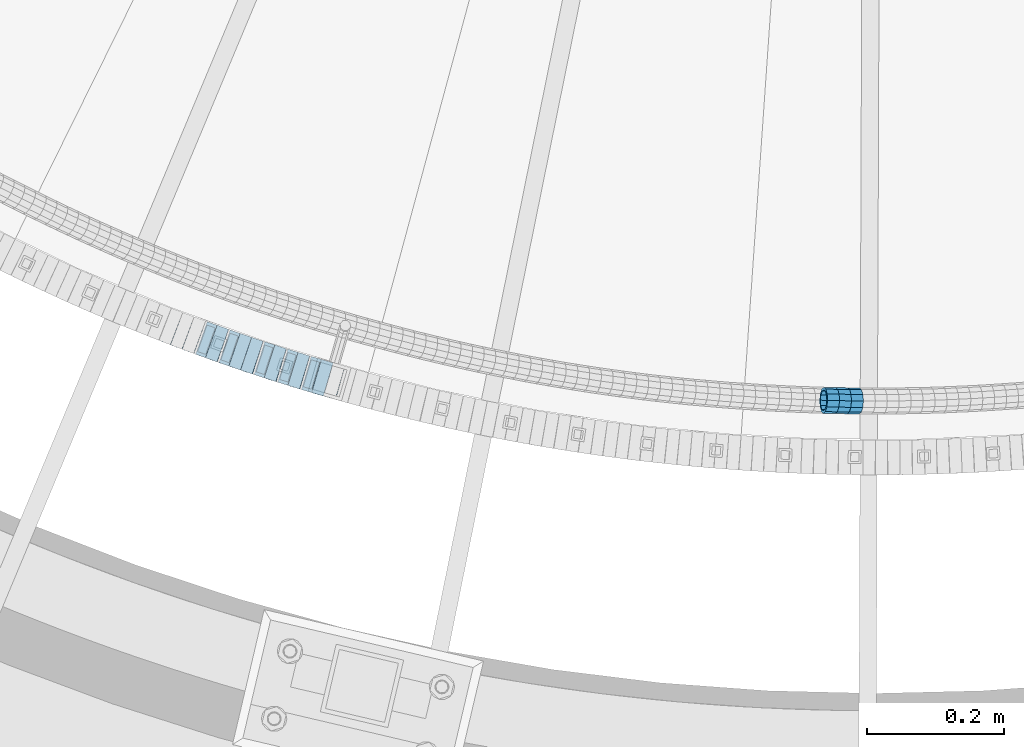
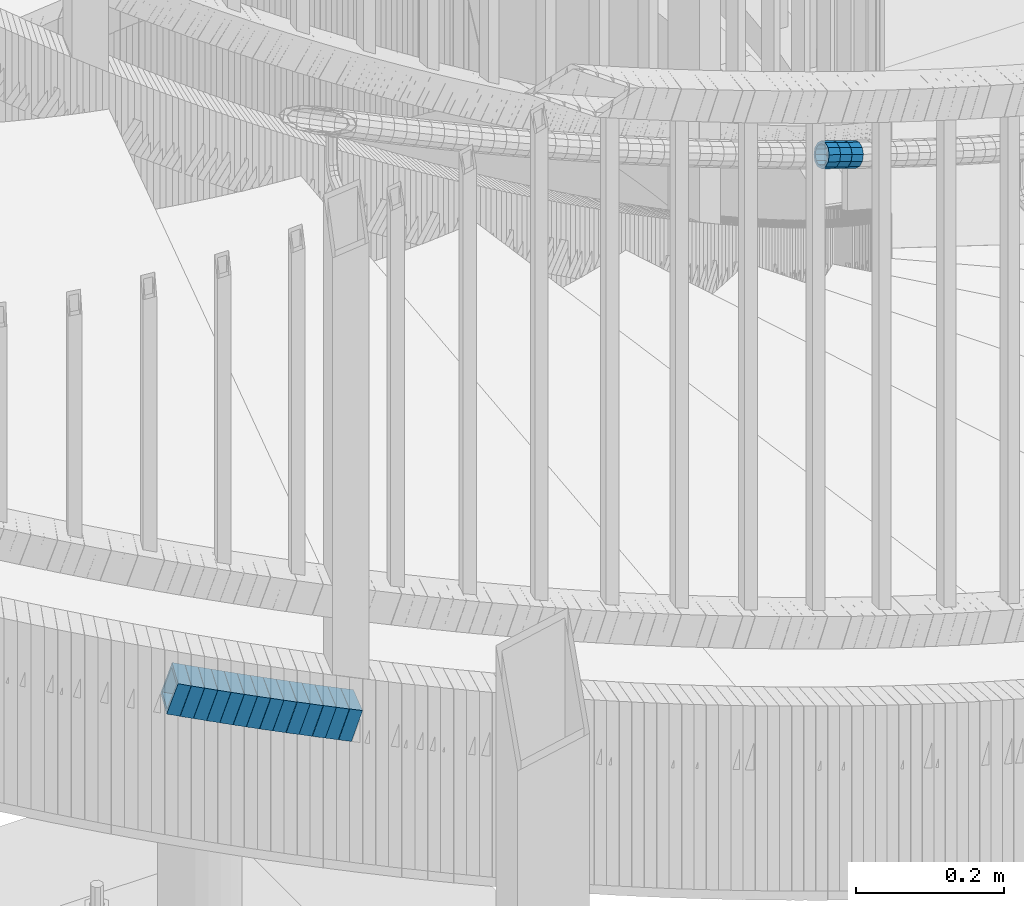
# One storey, part 670 of 975: 17 beams.
"""IFC2X3 building model written with IfcOpenShell, lengths in millimetres."""

from ifc_helpers import new_model, si_unit, frame, origin_with_axes, place, context, subcontext, project, spatial, faceted_brep, material, type_object, element, save


model = new_model("IFC2X3")

# Units and contexts
model_context = context("Model", 3, precision=1e-05, world=origin_with_axes())
body_context = subcontext(model_context, "Body", "Model", "MODEL_VIEW")
ifc_project = project(units=[si_unit("LENGTHUNIT", "METRE", prefix="MILLI"), si_unit("AREAUNIT", "SQUARE_METRE"), si_unit("VOLUMEUNIT", "CUBIC_METRE"), si_unit("MASSUNIT", "GRAM", prefix="KILO"), si_unit("TIMEUNIT", "SECOND"), si_unit("PLANEANGLEUNIT", "RADIAN"), si_unit("SOLIDANGLEUNIT", "STERADIAN"), si_unit("THERMODYNAMICTEMPERATUREUNIT", "DEGREE_CELSIUS"), si_unit("LUMINOUSINTENSITYUNIT", "LUMEN")], contexts=[model_context])

# Site, building, storey
site_placement = place(None, origin_with_axes())
site = spatial("IfcSite", under=ifc_project, at=site_placement, CompositionType="ELEMENT")
building_placement = place(site_placement, origin_with_axes())
building = spatial("IfcBuilding", under=site, at=building_placement, Name="Undefined", CompositionType="ELEMENT")
storey_placement = place(building_placement, origin_with_axes())
storey = spatial("IfcBuildingStorey", under=building, at=storey_placement, Name="Undefined", CompositionType="ELEMENT", Elevation=0.0)

# Beams
ifc_material = material()
beam_type_1 = type_object("IfcBeamType", PredefinedType="NOTDEFINED")
beam_1_placement = place(storey_placement, frame((34658.2997563752, 616.742176739283, 4234.28615439462), z_axis=(0.0228511744520583, 0.999738877820685, -1.48498656926677e-10), x_axis=(0.950609749720735, -0.0217282229936169, -0.309627175909061)))
element("IfcBeam", 1, at=beam_1_placement, inside=storey, type_object=beam_type_1, material=ifc_material, Name="WALL", context=body_context, shape_type="Brep", body=[
    faceted_brep([(-2.1246523829177e-07, -15.367000000002, 0.0), (-1.83998054126278e-07, -13.3082123799541, 7.68350000000009), (18.4143965418989, -13.3082123799722, 7.68350000004284), (18.4143965419134, -15.3670000000257, 5.82076609134674e-11), (-1.06232619145885e-07, -7.68349999999919, 13.3082123799559), (18.4143965418734, -7.68350000000646, 13.3082123799759), (-3.63797880709171e-12, 3.63797880709171e-12, 15.3670000000002), (18.414396541848, 3.63797880709171e-12, 15.3669999999984), (1.06225343188271e-07, 7.68350000000646, 13.3082123799559), (18.4143965418334, 7.6835000000101, 13.3082123799395), (1.8399441614747e-07, 13.308212379965, 7.68350000000009), (18.4143965418261, 13.3082123799686, 7.68349999997736), (2.12461600312963e-07, 15.3670000000093, 0.0), (18.4143965418334, 15.3670000000093, -1.81898940354586e-11), (1.8399441614747e-07, 13.308212379965, -7.68350000000009), (18.4143965418552, 13.3082123799577, -7.68349999999919), (1.06225343188271e-07, 7.68350000000646, -13.3082123799559), (18.4143965418734, 7.68349999999191, -13.3082123799322), (-3.63797880709171e-12, 3.63797880709171e-12, -15.3670000000002), (18.4143965418989, -2.00088834390044e-11, -15.3669999999584), (-1.06232619145885e-07, -7.68349999999919, -13.3082123799559), (18.4143965419134, -7.68350000002829, -13.3082123798958), (-1.83998054126278e-07, -13.3082123799541, -7.68350000000009), (18.4143965419207, -13.3082123799832, -7.6834999999337), (-2.63386027654633e-07, -19.0500000000029, 0.0), (-2.28097633225843e-07, -16.4977839420972, -9.52499999999964), (18.4143965419316, -16.4977839421263, -9.5249999999287), (18.4143965419207, -19.0500000000284, 6.54836185276508e-11), (-1.31691194837913e-07, -9.52500000000146, -16.4977839420935), (18.4143965419207, -9.52500000003056, -16.497783942028), (-3.63797880709171e-12, 3.63797880709171e-12, -19.0500000000002), (18.4143965419025, -2.18278728425503e-11, -19.049999999952), (1.31687556859106e-07, 9.52500000000509, -16.4977839420935), (18.4143965418771, 9.52499999999054, -16.4977839420717), (2.28097633225843e-07, 16.4977839421044, -9.52499999999964), (18.414396541848, 16.4977839420972, -9.52500000000146), (2.63382389675826e-07, 19.0500000000138, 0.0), (18.4143965418298, 19.050000000012, -2.18278728425503e-11), (2.28097633225843e-07, 16.4977839421044, 9.52499999999964), (18.4143965418225, 16.4977839421117, 9.52499999997235), (1.31687556859106e-07, 9.52500000000509, 16.4977839420935), (18.4143965418225, 9.52500000001601, 16.4977839420681), (-3.63797880709171e-12, 3.63797880709171e-12, 19.0500000000002), (18.4143965418443, 7.27595761418343e-12, 19.0499999999956), (-1.31691194837913e-07, -9.52500000000146, 16.4977839420935), (18.4143965418734, -9.52500000000691, 16.4977839421153), (-2.28097633225843e-07, -16.4977839420972, 9.52499999999964), (18.4143965418989, -16.4977839421117, 9.52500000004511)], [[[0, 1, 2, 3]], [[1, 4, 5, 2]], [[4, 6, 7, 5]], [[6, 8, 9, 7]], [[8, 10, 11, 9]], [[10, 12, 13, 11]], [[12, 14, 15, 13]], [[14, 16, 17, 15]], [[16, 18, 19, 17]], [[18, 20, 21, 19]], [[20, 22, 23, 21]], [[22, 0, 3, 23]], [[24, 25, 26, 27]], [[25, 28, 29, 26]], [[28, 30, 31, 29]], [[30, 32, 33, 31]], [[32, 34, 35, 33]], [[34, 36, 37, 35]], [[36, 38, 39, 37]], [[38, 40, 41, 39]], [[40, 42, 43, 41]], [[42, 44, 45, 43]], [[44, 46, 47, 45]], [[46, 24, 27, 47]], [[29, 31, 33, 35, 37, 39, 41, 43, 45, 47, 27, 26], [5, 7, 9, 11, 13, 15, 17, 19, 21, 23, 3, 2]], [[46, 44, 42, 40, 38, 36, 34, 32, 30, 28, 25, 24], [22, 20, 18, 16, 14, 12, 10, 8, 6, 4, 1, 0]]]),
])
beam_2_placement = place(storey_placement, frame((34675.7051563628, 616.310102125256, 4228.61701392285), z_axis=(0.0171403388856634, 0.999853093600697, 3.56149030267261e-11), x_axis=(0.949098667936457, -0.0162702629989103, -0.314558415978955)))
element("IfcBeam", 2, at=beam_2_placement, inside=storey, type_object=beam_type_1, material=ifc_material, Name="WALL", context=body_context, shape_type="Brep", body=[
    faceted_brep([(-2.1246523829177e-07, -15.367000000002, 0.0), (-1.83998054126278e-07, -13.3082123799541, 7.68350000000009), (18.4442402933746, -13.3082123799431, 7.68349999998463), (18.4442402933928, -15.3669999999893, -3.63797880709171e-12), (-1.06232619145885e-07, -7.68349999999919, 13.3082123799559), (18.4442402933564, -7.68349999998281, 13.308212379925), (-3.63797880709171e-12, 3.63797880709171e-12, 15.3670000000002), (18.4442402933455, 1.81898940354586e-11, 15.3669999999584), (1.06225343188271e-07, 7.68350000000646, 13.3082123799559), (18.4442402933419, 7.68350000001737, 13.3082123799104), (1.8399441614747e-07, 13.308212379965, 7.68350000000009), (18.4442402933528, 13.3082123799722, 7.68349999996281), (2.12461600312963e-07, 15.3670000000093, 0.0), (18.4442402933637, 15.3670000000129, -2.5465851649642e-11), (1.8399441614747e-07, 13.308212379965, -7.68350000000009), (18.4442402933855, 13.308212379965, -7.6835000000101), (1.06225343188271e-07, 7.68350000000646, -13.3082123799559), (18.4442402934037, 7.68350000000646, -13.3082123799541), (-3.63797880709171e-12, 3.63797880709171e-12, -15.3670000000002), (18.444240293411, 5.45696821063757e-12, -15.3669999999911), (-1.06232619145885e-07, -7.68349999999919, -13.3082123799559), (18.4442402934146, -7.68349999999373, -13.3082123799431), (-1.83998054126278e-07, -13.3082123799541, -7.68350000000009), (18.4442402934037, -13.3082123799468, -7.68349999999191), (-2.63386027654633e-07, -19.0500000000029, 0.0), (-2.28097633225843e-07, -16.4977839420972, -9.52499999999964), (18.444240293411, -16.4977839420862, -9.5249999999869), (18.4442402933964, -19.0499999999902, 0.0), (-1.31691194837913e-07, -9.52500000000146, -16.4977839420935), (18.4442402934219, -9.524999999996, -16.4977839420717), (-3.63797880709171e-12, 3.63797880709171e-12, -19.0500000000002), (18.4442402934183, 3.63797880709171e-12, -19.0499999999847), (1.31687556859106e-07, 9.52500000000509, -16.4977839420935), (18.4442402934073, 9.52500000000509, -16.4977839420899), (2.28097633225843e-07, 16.4977839421044, -9.52499999999964), (18.4442402933855, 16.4977839421008, -9.52500000001601), (2.63382389675826e-07, 19.0500000000138, 0.0), (18.4442402933637, 19.0500000000138, -2.91038304567337e-11), (2.28097633225843e-07, 16.4977839421044, 9.52499999999964), (18.4442402933419, 16.4977839421117, 9.52499999995052), (1.31687556859106e-07, 9.52500000000509, 16.4977839420935), (18.4442402933346, 9.52500000001965, 16.4977839420426), (-3.63797880709171e-12, 3.63797880709171e-12, 19.0500000000002), (18.4442402933346, 2.00088834390044e-11, 19.0499999999483), (-1.31691194837913e-07, -9.52500000000146, 16.4977839420935), (18.4442402933528, -9.52499999998145, 16.4977839420571), (-2.28097633225843e-07, -16.4977839420972, 9.52499999999964), (18.4442402933746, -16.497783942079, 9.52499999998327)], [[[0, 1, 2, 3]], [[1, 4, 5, 2]], [[4, 6, 7, 5]], [[6, 8, 9, 7]], [[8, 10, 11, 9]], [[10, 12, 13, 11]], [[12, 14, 15, 13]], [[14, 16, 17, 15]], [[16, 18, 19, 17]], [[18, 20, 21, 19]], [[20, 22, 23, 21]], [[22, 0, 3, 23]], [[24, 25, 26, 27]], [[25, 28, 29, 26]], [[28, 30, 31, 29]], [[30, 32, 33, 31]], [[32, 34, 35, 33]], [[34, 36, 37, 35]], [[36, 38, 39, 37]], [[38, 40, 41, 39]], [[40, 42, 43, 41]], [[42, 44, 45, 43]], [[44, 46, 47, 45]], [[46, 24, 27, 47]], [[29, 31, 33, 35, 37, 39, 41, 43, 45, 47, 27, 26], [5, 7, 9, 11, 13, 15, 17, 19, 21, 23, 3, 2]], [[46, 44, 42, 40, 38, 36, 34, 32, 30, 28, 25, 24], [22, 20, 18, 16, 14, 12, 10, 8, 6, 4, 1, 0]]]),
])
beam_3_placement = place(storey_placement, frame((34693.2970067183, 615.941103466021, 4222.78657964472), z_axis=(0.00571419214249181, 0.999983673870808, -4.66516212327406e-11), x_axis=(0.950820193716176, -0.00543325799837793, -0.309695719907553)))
element("IfcBeam", 3, at=beam_3_placement, inside=storey, type_object=beam_type_1, material=ifc_material, Name="WALL", context=body_context, shape_type="Brep", body=[
    faceted_brep([(-2.1246523829177e-07, -15.367000000002, 0.0), (-1.83998054126278e-07, -13.3082123799541, 7.68350000000009), (18.4143965418989, -13.3082123799722, 7.68350000004284), (18.4143965419134, -15.3670000000257, 5.82076609134674e-11), (-1.06232619145885e-07, -7.68349999999919, 13.3082123799559), (18.4143965418734, -7.68350000000646, 13.3082123799759), (-3.63797880709171e-12, 3.63797880709171e-12, 15.3670000000002), (18.414396541848, 3.63797880709171e-12, 15.3669999999984), (1.06225343188271e-07, 7.68350000000646, 13.3082123799559), (18.4143965418334, 7.6835000000101, 13.3082123799395), (1.8399441614747e-07, 13.308212379965, 7.68350000000009), (18.4143965418261, 13.3082123799686, 7.68349999997736), (2.12461600312963e-07, 15.3670000000093, 0.0), (18.4143965418334, 15.3670000000093, -1.81898940354586e-11), (1.8399441614747e-07, 13.308212379965, -7.68350000000009), (18.4143965418552, 13.3082123799577, -7.68349999999919), (1.06225343188271e-07, 7.68350000000646, -13.3082123799559), (18.4143965418734, 7.68349999999191, -13.3082123799322), (-3.63797880709171e-12, 3.63797880709171e-12, -15.3670000000002), (18.4143965418989, -2.00088834390044e-11, -15.3669999999584), (-1.06232619145885e-07, -7.68349999999919, -13.3082123799559), (18.4143965419134, -7.68350000002829, -13.3082123798958), (-1.83998054126278e-07, -13.3082123799541, -7.68350000000009), (18.4143965419207, -13.3082123799832, -7.6834999999337), (-2.63386027654633e-07, -19.0500000000029, 0.0), (-2.28097633225843e-07, -16.4977839420972, -9.52499999999964), (18.4143965419316, -16.4977839421263, -9.5249999999287), (18.4143965419207, -19.0500000000284, 6.54836185276508e-11), (-1.31691194837913e-07, -9.52500000000146, -16.4977839420935), (18.4143965419207, -9.52500000003056, -16.497783942028), (-3.63797880709171e-12, 3.63797880709171e-12, -19.0500000000002), (18.4143965419025, -2.18278728425503e-11, -19.049999999952), (1.31687556859106e-07, 9.52500000000509, -16.4977839420935), (18.4143965418771, 9.52499999999054, -16.4977839420717), (2.28097633225843e-07, 16.4977839421044, -9.52499999999964), (18.414396541848, 16.4977839420972, -9.52500000000146), (2.63382389675826e-07, 19.0500000000138, 0.0), (18.4143965418298, 19.050000000012, -2.18278728425503e-11), (2.28097633225843e-07, 16.4977839421044, 9.52499999999964), (18.4143965418225, 16.4977839421117, 9.52499999997235), (1.31687556859106e-07, 9.52500000000509, 16.4977839420935), (18.4143965418225, 9.52500000001601, 16.4977839420681), (-3.63797880709171e-12, 3.63797880709171e-12, 19.0500000000002), (18.4143965418443, 7.27595761418343e-12, 19.0499999999956), (-1.31691194837913e-07, -9.52500000000146, 16.4977839420935), (18.4143965418734, -9.52500000000691, 16.4977839421153), (-2.28097633225843e-07, -16.4977839420972, 9.52499999999964), (18.4143965418989, -16.4977839421117, 9.52500000004511)], [[[0, 1, 2, 3]], [[1, 4, 5, 2]], [[4, 6, 7, 5]], [[6, 8, 9, 7]], [[8, 10, 11, 9]], [[10, 12, 13, 11]], [[12, 14, 15, 13]], [[14, 16, 17, 15]], [[16, 18, 19, 17]], [[18, 20, 21, 19]], [[20, 22, 23, 21]], [[22, 0, 3, 23]], [[24, 25, 26, 27]], [[25, 28, 29, 26]], [[28, 30, 31, 29]], [[30, 32, 33, 31]], [[32, 34, 35, 33]], [[34, 36, 37, 35]], [[36, 38, 39, 37]], [[38, 40, 41, 39]], [[40, 42, 43, 41]], [[42, 44, 45, 43]], [[44, 46, 47, 45]], [[46, 24, 27, 47]], [[29, 31, 33, 35, 37, 39, 41, 43, 45, 47, 27, 26], [5, 7, 9, 11, 13, 15, 17, 19, 21, 23, 3, 2]], [[46, 44, 42, 40, 38, 36, 34, 32, 30, 28, 25, 24], [22, 20, 18, 16, 14, 12, 10, 8, 6, 4, 1, 0]]]),
])
beam_type_2 = type_object("IfcBeamType", Name="HSS2X2X.188_TUBES", PredefinedType="NOTDEFINED")
beam_4_placement = place(storey_placement, frame((33703.3554317034, 724.379436873648, 3623.64339132083), z_axis=(0.352964717887473, 0.935636632420202, 8.24084054329433e-11), x_axis=(0.889834960856946, -0.335686242946032, -0.309044476950317)))
element("IfcBeam", 4, at=beam_4_placement, inside=storey, type_object=beam_type_2, material=ifc_material, Name="WALL", ObjectType="HSS2X2X.188_TUBES", context=body_context, shape_type="Brep", body=[
    faceted_brep([(0.0, 20.6374999999753, -20.6375000000298), (0.0, -20.6375000000153, -20.6375000000153), (18.767258723612, -20.6375000000025, -20.6374999999862), (18.7672587236229, 20.6374999999953, -20.637499999968), (0.0, -20.6374999999825, 20.6375000000335), (18.767258723612, -20.6375000000135, 20.6375000000153), (0.0, 20.6375000000116, 20.6375000000189), (18.7672587236266, 20.6374999999844, 20.6375000000371), (0.0, 25.3999999999724, -25.4000000000342), (0.0, 25.400000000016, 25.4000000000196), (18.7672587236302, 25.3999999999814, 25.4000000000342), (18.7672587236229, 25.399999999996, -25.3999999999687), (0.0, -25.399999999976, 25.4000000000378), (18.7672587236157, -25.4000000000142, 25.400000000016), (0.0, -25.400000000016, -25.4000000000196), (18.767258723612, -25.4000000000015, -25.3999999999905)], [[[0, 1, 2, 3]], [[1, 4, 5, 2]], [[4, 6, 7, 5]], [[6, 0, 3, 7]], [[8, 9, 10, 11]], [[9, 12, 13, 10]], [[12, 14, 15, 13]], [[14, 8, 11, 15]], [[13, 15, 11, 10], [5, 7, 3, 2]], [[14, 12, 9, 8], [6, 4, 1, 0]]]),
])
beam_5_placement = place(storey_placement, frame((33720.3436374775, 717.912164886869, 3617.79652348214), z_axis=(0.346222870079248, 0.938152292665795, -6.04968590778299e-11), x_axis=(0.893958542957784, -0.329913271984421, -0.303307362985684)))
element("IfcBeam", 5, at=beam_5_placement, inside=storey, type_object=beam_type_2, material=ifc_material, Name="WALL", ObjectType="HSS2X2X.188_TUBES", context=body_context, shape_type="Brep", body=[
    faceted_brep([(0.0, 20.6374999999753, -20.6375000000298), (0.0, -20.6375000000153, -20.6375000000153), (18.7853666454903, -20.6375000000535, -20.6375000000326), (18.785366645363, 20.6374999999862, -20.6375000000044), (0.0, -20.6374999999825, 20.6375000000335), (18.785366645352, -20.6375000000007, 20.6374999999989), (0.0, 20.6375000000116, 20.6375000000189), (18.7853666453102, 20.6375000000025, 20.6374999999753), (0.0, 25.3999999999724, -25.4000000000342), (0.0, 25.400000000016, 25.4000000000196), (18.7853666452065, 25.4000000000451, 25.4000000000351), (18.7853666453739, 25.3999999999833, -25.400000000006), (0.0, -25.399999999976, 25.4000000000378), (18.7853666497213, -25.399999993424, 25.3999999995158), (0.0, -25.400000000016, -25.4000000000196), (18.7853666455194, -25.4000000000633, -25.4000000000406)], [[[0, 1, 2, 3]], [[1, 4, 5, 2]], [[4, 6, 7, 5]], [[6, 0, 3, 7]], [[8, 9, 10, 11]], [[9, 12, 13, 10]], [[12, 14, 15, 13]], [[14, 8, 11, 15]], [[13, 15, 11, 10], [5, 7, 3, 2]], [[14, 12, 9, 8], [6, 4, 1, 0]]]),
])
beam_6_placement = place(storey_placement, frame((33737.2422920405, 711.632950605115, 3612.10080897252), z_axis=(0.34129379192293, 0.939956673254075, 5.07570803165435e-11), x_axis=(0.895519334726754, -0.325158805900785, -0.30383691690729)))
element("IfcBeam", 6, at=beam_6_placement, inside=storey, type_object=beam_type_2, material=ifc_material, Name="WALL", ObjectType="HSS2X2X.188_TUBES", context=body_context, shape_type="Brep", body=[
    faceted_brep([(0.0, 20.6374999999753, -20.6375000000298), (0.0, -20.6375000000153, -20.6375000000153), (18.7555325170906, -20.6374999999916, -20.6374999999971), (18.7555325171452, 20.637499999988, -20.6374999999571), (0.0, -20.6374999999825, 20.6375000000335), (18.7555325170615, -20.6374999999844, 20.6374999999716), (0.0, 20.6375000000116, 20.6375000000189), (18.7555325171015, 20.6374999999953, 20.637500000008), (0.0, 25.3999999999724, -25.4000000000342), (0.0, 25.400000000016, 25.4000000000196), (18.7555325171015, 25.399999999996, 25.4000000000051), (18.7555325171488, 25.3999999999851, -25.3999999999505), (0.0, -25.399999999976, 25.4000000000378), (18.755532517047, -25.3999999999814, 25.3999999999578), (0.0, -25.400000000016, -25.4000000000196), (18.7555325170979, -25.3999999999924, -25.3999999999978)], [[[0, 1, 2, 3]], [[1, 4, 5, 2]], [[4, 6, 7, 5]], [[6, 0, 3, 7]], [[8, 9, 10, 11]], [[9, 12, 13, 10]], [[12, 14, 15, 13]], [[14, 8, 11, 15]], [[13, 15, 11, 10], [5, 7, 3, 2]], [[14, 12, 9, 8], [6, 4, 1, 0]]]),
])
beam_7_placement = place(storey_placement, frame((33754.1419063121, 705.453820656643, 3606.40505485752), z_axis=(0.336336396745049, 0.941741911685233, 4.28894963988568e-11), x_axis=(0.897062751785234, -0.320379553923298, -0.304360576927124)))
element("IfcBeam", 7, at=beam_7_placement, inside=storey, type_object=beam_type_2, material=ifc_material, Name="WALL", ObjectType="HSS2X2X.188_TUBES", context=body_context, shape_type="Brep", body=[
    faceted_brep([(0.0, 20.6374999999753, -20.6375000000298), (0.0, -20.6375000000153, -20.6375000000153), (18.7347271129966, -20.6375000000116, -20.6375000000262), (18.7347271130257, 20.6374999999989, -20.6374999999935), (0.0, -20.6374999999825, 20.6375000000335), (18.7347271129947, -20.6375000000116, 20.6374999999607), (0.0, 20.6375000000116, 20.6375000000189), (18.7347271130147, 20.6375000000007, 20.6374999999898), (0.0, 25.3999999999724, -25.4000000000342), (0.0, 25.400000000016, 25.4000000000196), (18.7347271130166, 25.4000000000015, 25.3999999999905), (18.7347271130257, 25.3999999999996, -25.3999999999869), (0.0, -25.399999999976, 25.4000000000378), (18.7347271129875, -25.4000000000106, 25.3999999999505), (0.0, -25.400000000016, -25.4000000000196), (18.7347271130002, -25.4000000000124, -25.4000000000233)], [[[0, 1, 2, 3]], [[1, 4, 5, 2]], [[4, 6, 7, 5]], [[6, 0, 3, 7]], [[8, 9, 10, 11]], [[9, 12, 13, 10]], [[12, 14, 15, 13]], [[14, 8, 11, 15]], [[13, 15, 11, 10], [5, 7, 3, 2]], [[14, 12, 9, 8], [6, 4, 1, 0]]]),
])
beam_8_placement = place(storey_placement, frame((33771.0014943915, 699.373867363563, 3600.73676420078), z_axis=(0.329603795288982, 0.944119345279557, -5.85469024372288e-11), x_axis=(0.898148754736519, -0.313554890908016, -0.308240400909585)))
element("IfcBeam", 8, at=beam_8_placement, inside=storey, type_object=beam_type_2, material=ifc_material, Name="WALL", ObjectType="HSS2X2X.188_TUBES", context=body_context, shape_type="Brep", body=[
    faceted_brep([(0.0, 20.6374999999753, -20.6375000000298), (0.0, -20.6375000000153, -20.6375000000153), (18.8225928075335, -20.6374999999935, -20.6375000000298), (18.8225928075699, 20.6374999999898, -20.6374999999825), (0.0, -20.6374999999825, 20.6375000000335), (18.8225928075772, -20.637500000008, 20.6375000000226), (0.0, 20.6375000000116, 20.6375000000189), (18.8225928076135, 20.6374999999753, 20.6375000000698), (0.0, 25.3999999999724, -25.4000000000342), (0.0, 25.400000000016, 25.4000000000196), (18.8225928076281, 25.3999999999705, 25.4000000000815), (18.8225928075663, 25.3999999999905, -25.3999999999796), (0.0, -25.399999999976, 25.4000000000378), (18.8225928075808, -25.4000000000087, 25.4000000000233), (0.0, -25.400000000016, -25.4000000000196), (18.8225928075226, -25.3999999999905, -25.4000000000378)], [[[0, 1, 2, 3]], [[1, 4, 5, 2]], [[4, 6, 7, 5]], [[6, 0, 3, 7]], [[8, 9, 10, 11]], [[9, 12, 13, 10]], [[12, 14, 15, 13]], [[14, 8, 11, 15]], [[13, 15, 11, 10], [5, 7, 3, 2]], [[14, 12, 9, 8], [6, 4, 1, 0]]]),
])
beam_9_placement = place(storey_placement, frame((33788.1185087101, 693.355275724624, 3594.90150870524), z_axis=(0.324610482431657, 0.945847786219055, 1.94175299839116e-10), x_axis=(0.90110588298714, -0.309255272995583, -0.303923285995651)))
element("IfcBeam", 9, at=beam_9_placement, inside=storey, type_object=beam_type_2, material=ifc_material, Name="WALL", ObjectType="HSS2X2X.188_TUBES", context=body_context, shape_type="Brep", body=[
    faceted_brep([(0.0, 20.6374999999753, -20.6375000000298), (0.0, -20.6375000000153, -20.6375000000153), (18.7547327359644, -20.6374999999844, -20.6375000000553), (18.7547327359898, 20.6375000000171, -20.6375000000335), (0.0, -20.6374999999825, 20.6375000000335), (18.7547327360044, -20.6374999999953, 20.6374999999898), (0.0, 20.6375000000116, 20.6375000000189), (18.7547327360262, 20.6375000000062, 20.6375000000116), (0.0, 25.3999999999724, -25.4000000000342), (0.0, 25.400000000016, 25.4000000000196), (18.7547327360371, 25.4000000000033, 25.4000000000124), (18.7547327359898, 25.4000000000178, -25.4000000000342), (0.0, -25.399999999976, 25.4000000000378), (18.7547327360044, -25.399999999996, 25.3999999999869), (0.0, -25.400000000016, -25.4000000000196), (18.7547327359498, -25.3999999999814, -25.4000000000597)], [[[0, 1, 2, 3]], [[1, 4, 5, 2]], [[4, 6, 7, 5]], [[6, 0, 3, 7]], [[8, 9, 10, 11]], [[9, 12, 13, 10]], [[12, 14, 15, 13]], [[14, 8, 11, 15]], [[13, 15, 11, 10], [5, 7, 3, 2]], [[14, 12, 9, 8], [6, 4, 1, 0]]]),
])
beam_10_placement = place(storey_placement, frame((33805.1208582981, 687.477173678062, 3589.20554805691), z_axis=(0.319589881675179, 0.947555965381911, 1.3737371773459e-10), x_axis=(0.90258256992662, -0.304421339975253, -0.304421339975253)))
element("IfcBeam", 10, at=beam_10_placement, inside=storey, type_object=beam_type_2, material=ifc_material, Name="WALL", ObjectType="HSS2X2X.188_TUBES", context=body_context, shape_type="Brep", body=[
    faceted_brep([(0.0, 20.6374999999753, -20.6375000000298), (0.0, -20.6375000000153, -20.6375000000153), (18.724849799155, -20.6375000000171, -20.6374999999425), (18.7248497991204, 20.6374999999989, -20.6375000000007), (0.0, -20.6374999999825, 20.6375000000335), (18.7248497991168, -20.6374999999953, 20.6375000000007), (0.0, 20.6375000000116, 20.6375000000189), (18.724849799084, 20.6375000000226, 20.6374999999498), (0.0, 25.3999999999724, -25.4000000000342), (0.0, 25.400000000016, 25.4000000000196), (18.7248497990731, 25.4000000000269, 25.399999999936), (18.7248497991204, 25.3999999999978, -25.3999999999978), (0.0, -25.399999999976, 25.4000000000378), (18.7248497991186, -25.3999999999942, 25.4000000000051), (0.0, -25.400000000016, -25.4000000000196), (18.7248497991604, -25.4000000000233, -25.3999999999323)], [[[0, 1, 2, 3]], [[1, 4, 5, 2]], [[4, 6, 7, 5]], [[6, 0, 3, 7]], [[8, 9, 10, 11]], [[9, 12, 13, 10]], [[12, 14, 15, 13]], [[14, 8, 11, 15]], [[13, 15, 11, 10], [5, 7, 3, 2]], [[14, 12, 9, 8], [6, 4, 1, 0]]]),
])
beam_11_placement = place(storey_placement, frame((33822.1851059751, 681.62125007683, 3583.54096997326), z_axis=(0.307820284834634, 0.951444518742068, 2.53007783612702e-11), x_axis=(0.904959712713077, -0.292781082907172, -0.308750960902098)))
element("IfcBeam", 11, at=beam_11_placement, inside=storey, type_object=beam_type_2, material=ifc_material, Name="WALL", ObjectType="HSS2X2X.188_TUBES", context=body_context, shape_type="Brep", body=[
    faceted_brep([(0.0, 20.6374999999753, -20.6375000000298), (0.0, -20.6375000000153, -20.6375000000153), (18.7853666454903, -20.6375000000535, -20.6375000000326), (18.785366645363, 20.6374999999862, -20.6375000000044), (0.0, -20.6374999999825, 20.6375000000335), (18.785366645352, -20.6375000000007, 20.6374999999989), (0.0, 20.6375000000116, 20.6375000000189), (18.7853666453102, 20.6375000000025, 20.6374999999753), (0.0, 25.3999999999724, -25.4000000000342), (0.0, 25.400000000016, 25.4000000000196), (18.7853666452065, 25.4000000000451, 25.4000000000351), (18.7853666453739, 25.3999999999833, -25.400000000006), (0.0, -25.399999999976, 25.4000000000378), (18.7853666497213, -25.399999993424, 25.3999999995158), (0.0, -25.400000000016, -25.4000000000196), (18.7853666455194, -25.4000000000633, -25.4000000000406)], [[[0, 1, 2, 3]], [[1, 4, 5, 2]], [[4, 6, 7, 5]], [[6, 0, 3, 7]], [[8, 9, 10, 11]], [[9, 12, 13, 10]], [[12, 14, 15, 13]], [[14, 8, 11, 15]], [[13, 15, 11, 10], [5, 7, 3, 2]], [[14, 12, 9, 8], [6, 4, 1, 0]]]),
])
beam_12_placement = place(storey_placement, frame((33839.3017748998, 676.083504248275, 3577.70150870524), z_axis=(0.307820284834634, 0.951444518742068, 2.53007783612702e-11), x_axis=(0.906437870257715, -0.293259311083381, -0.303923286086404)))
element("IfcBeam", 12, at=beam_12_placement, inside=storey, type_object=beam_type_2, material=ifc_material, Name="WALL", ObjectType="HSS2X2X.188_TUBES", context=body_context, shape_type="Brep", body=[
    faceted_brep([(0.0, 20.6374999999753, -20.6375000000298), (0.0, -20.6375000000153, -20.6375000000153), (18.7547327359644, -20.6374999999844, -20.6375000000553), (18.7547327359898, 20.6375000000171, -20.6375000000335), (0.0, -20.6374999999825, 20.6375000000335), (18.7547327360044, -20.6374999999953, 20.6374999999898), (0.0, 20.6375000000116, 20.6375000000189), (18.7547327360262, 20.6375000000062, 20.6375000000116), (0.0, 25.3999999999724, -25.4000000000342), (0.0, 25.400000000016, 25.4000000000196), (18.7547327360371, 25.4000000000033, 25.4000000000124), (18.7547327359898, 25.4000000000178, -25.4000000000342), (0.0, -25.399999999976, 25.4000000000378), (18.7547327360044, -25.399999999996, 25.3999999999869), (0.0, -25.400000000016, -25.4000000000196), (18.7547327359498, -25.3999999999814, -25.4000000000597)], [[[0, 1, 2, 3]], [[1, 4, 5, 2]], [[4, 6, 7, 5]], [[6, 0, 3, 7]], [[8, 9, 10, 11]], [[9, 12, 13, 10]], [[12, 14, 15, 13]], [[14, 8, 11, 15]], [[13, 15, 11, 10], [5, 7, 3, 2]], [[14, 12, 9, 8], [6, 4, 1, 0]]]),
])
beam_13_placement = place(storey_placement, frame((33856.5850794483, 670.393868230358, 3571.9971487143), z_axis=(0.296047809689779, 0.955173122725867, 6.85054146742914e-11), x_axis=(0.910154056928473, -0.282094531977832, -0.303384685976155)))
element("IfcBeam", 13, at=beam_13_placement, inside=storey, type_object=beam_type_2, material=ifc_material, Name="WALL", ObjectType="HSS2X2X.188_TUBES", context=body_context, shape_type="Brep", body=[
    faceted_brep([(0.0, 20.6374999999753, -20.6375000000298), (0.0, -20.6375000000153, -20.6375000000153), (18.7853666454903, -20.6375000000535, -20.6375000000326), (18.785366645363, 20.6374999999862, -20.6375000000044), (0.0, -20.6374999999825, 20.6375000000335), (18.785366645352, -20.6375000000007, 20.6374999999989), (0.0, 20.6375000000116, 20.6375000000189), (18.7853666453102, 20.6375000000025, 20.6374999999753), (0.0, 25.3999999999724, -25.4000000000342), (0.0, 25.400000000016, 25.4000000000196), (18.7853666452065, 25.4000000000451, 25.4000000000351), (18.7853666453739, 25.3999999999833, -25.400000000006), (0.0, -25.399999999976, 25.4000000000378), (18.7853666497213, -25.399999993424, 25.3999999995158), (0.0, -25.400000000016, -25.4000000000196), (18.7853666455194, -25.4000000000633, -25.4000000000406)], [[[0, 1, 2, 3]], [[1, 4, 5, 2]], [[4, 6, 7, 5]], [[6, 0, 3, 7]], [[8, 9, 10, 11]], [[9, 12, 13, 10]], [[12, 14, 15, 13]], [[14, 8, 11, 15]], [[13, 15, 11, 10], [5, 7, 3, 2]], [[14, 12, 9, 8], [6, 4, 1, 0]]]),
])
beam_14_placement = place(storey_placement, frame((33873.568117732, 665.130119522527, 3566.33647766828), z_axis=(0.296047809689779, 0.955173122725867, 6.85054146742914e-11), x_axis=(0.908675082134323, -0.281636137041631, -0.308205583045554)))
element("IfcBeam", 14, at=beam_14_placement, inside=storey, type_object=beam_type_2, material=ifc_material, Name="WALL", ObjectType="HSS2X2X.188_TUBES", context=body_context, shape_type="Brep", body=[
    faceted_brep([(0.0, 20.6374999999753, -20.6375000000298), (0.0, -20.6375000000153, -20.6375000000153), (18.8225928075335, -20.6374999999935, -20.6375000000298), (18.8225928075699, 20.6374999999898, -20.6374999999825), (0.0, -20.6374999999825, 20.6375000000335), (18.8225928075772, -20.637500000008, 20.6375000000226), (0.0, 20.6375000000116, 20.6375000000189), (18.8225928076135, 20.6374999999753, 20.6375000000698), (0.0, 25.3999999999724, -25.4000000000342), (0.0, 25.400000000016, 25.4000000000196), (18.8225928076281, 25.3999999999705, 25.4000000000815), (18.8225928075663, 25.3999999999905, -25.3999999999796), (0.0, -25.399999999976, 25.4000000000378), (18.8225928075808, -25.4000000000087, 25.4000000000233), (0.0, -25.400000000016, -25.4000000000196), (18.8225928075226, -25.3999999999905, -25.4000000000378)], [[[0, 1, 2, 3]], [[1, 4, 5, 2]], [[4, 6, 7, 5]], [[6, 0, 3, 7]], [[8, 9, 10, 11]], [[9, 12, 13, 10]], [[12, 14, 15, 13]], [[14, 8, 11, 15]], [[13, 15, 11, 10], [5, 7, 3, 2]], [[14, 12, 9, 8], [6, 4, 1, 0]]]),
])
beam_15_placement = place(storey_placement, frame((33890.9993890326, 659.642344239735, 3560.50442133703), z_axis=(0.285805121720856, 0.958287760747327, 6.23786036157981e-11), x_axis=(0.912847515999948, -0.272252767999985, -0.304282504999994)))
element("IfcBeam", 15, at=beam_15_placement, inside=storey, type_object=beam_type_2, material=ifc_material, Name="WALL", ObjectType="HSS2X2X.188_TUBES", context=body_context, shape_type="Brep", body=[
    faceted_brep([(0.0, 20.6374999999753, -20.6375000000298), (0.0, -20.6375000000153, -20.6375000000153), (18.7347271129966, -20.6375000000116, -20.6375000000262), (18.7347271130257, 20.6374999999989, -20.6374999999935), (0.0, -20.6374999999825, 20.6375000000335), (18.7347271129947, -20.6375000000116, 20.6374999999607), (0.0, 20.6375000000116, 20.6375000000189), (18.7347271130147, 20.6375000000007, 20.6374999999898), (0.0, 25.3999999999724, -25.4000000000342), (0.0, 25.400000000016, 25.4000000000196), (18.7347271130166, 25.4000000000015, 25.3999999999905), (18.7347271130257, 25.3999999999996, -25.3999999999869), (0.0, -25.399999999976, 25.4000000000378), (18.7347271129875, -25.4000000000106, 25.3999999999505), (0.0, -25.400000000016, -25.4000000000196), (18.7347271130002, -25.4000000000124, -25.4000000000233)], [[[0, 1, 2, 3]], [[1, 4, 5, 2]], [[4, 6, 7, 5]], [[6, 0, 3, 7]], [[8, 9, 10, 11]], [[9, 12, 13, 10]], [[12, 14, 15, 13]], [[14, 8, 11, 15]], [[13, 15, 11, 10], [5, 7, 3, 2]], [[14, 12, 9, 8], [6, 4, 1, 0]]]),
])
beam_16_placement = place(storey_placement, frame((33908.0533953054, 654.54310571592, 3554.8316623909), z_axis=(0.284278109884981, 0.958741861107682, 4.55479494121391e-11), x_axis=(0.912251849818002, -0.270493280946038, -0.307619809938633)))
element("IfcBeam", 16, at=beam_16_placement, inside=storey, type_object=beam_type_2, material=ifc_material, Name="WALL", ObjectType="HSS2X2X.188_TUBES", context=body_context, shape_type="Brep", body=[
    faceted_brep([(0.0, 20.6374999999753, -20.6375000000298), (0.0, -20.6375000000153, -20.6375000000153), (18.8480768248774, -20.6374999999716, -20.6375000000735), (18.8480768249356, 20.6375000000153, -20.6375000000226), (0.0, -20.6374999999825, 20.6375000000335), (18.8480768249283, -20.6374999999935, 20.6374999999716), (0.0, 20.6375000000116, 20.6375000000189), (18.8480768249865, 20.6374999999935, 20.6375000000262), (0.0, 25.3999999999724, -25.4000000000342), (0.0, 25.400000000016, 25.4000000000196), (18.848076825001, 25.3999999999887, 25.4000000000378), (18.8480768249392, 25.4000000000142, -25.4000000000233), (0.0, -25.399999999976, 25.4000000000378), (18.8480768249283, -25.399999999996, 25.3999999999833), (0.0, -25.400000000016, -25.4000000000196), (18.8480768248664, -25.3999999999687, -25.4000000000779)], [[[0, 1, 2, 3]], [[1, 4, 5, 2]], [[4, 6, 7, 5]], [[6, 0, 3, 7]], [[8, 9, 10, 11]], [[9, 12, 13, 10]], [[12, 14, 15, 13]], [[14, 8, 11, 15]], [[13, 15, 11, 10], [5, 7, 3, 2]], [[14, 12, 9, 8], [6, 4, 1, 0]]]),
])
beam_17_placement = place(storey_placement, frame((33925.5881411416, 649.259117416348, 3548.99941195074), z_axis=(0.273982549227207, 0.961734663365609, -3.7718109524576e-11), x_axis=(0.916320646003028, -0.261044835000864, -0.303664400000996)))
element("IfcBeam", 17, at=beam_17_placement, inside=storey, type_object=beam_type_2, material=ifc_material, Name="WALL", ObjectType="HSS2X2X.188_TUBES", context=body_context, shape_type="Brep", body=[
    faceted_brep([(0.0, 20.6374999999753, -20.6375000000298), (0.0, -20.6375000000153, -20.6375000000153), (18.767258723612, -20.6375000000025, -20.6374999999862), (18.7672587236229, 20.6374999999953, -20.637499999968), (0.0, -20.6374999999825, 20.6375000000335), (18.767258723612, -20.6375000000135, 20.6375000000153), (0.0, 20.6375000000116, 20.6375000000189), (18.7672587236266, 20.6374999999844, 20.6375000000371), (0.0, 25.3999999999724, -25.4000000000342), (0.0, 25.400000000016, 25.4000000000196), (18.7672587236302, 25.3999999999814, 25.4000000000342), (18.7672587236229, 25.399999999996, -25.3999999999687), (0.0, -25.399999999976, 25.4000000000378), (18.7672587236157, -25.4000000000142, 25.400000000016), (0.0, -25.400000000016, -25.4000000000196), (18.767258723612, -25.4000000000015, -25.3999999999905)], [[[0, 1, 2, 3]], [[1, 4, 5, 2]], [[4, 6, 7, 5]], [[6, 0, 3, 7]], [[8, 9, 10, 11]], [[9, 12, 13, 10]], [[12, 14, 15, 13]], [[14, 8, 11, 15]], [[13, 15, 11, 10], [5, 7, 3, 2]], [[14, 12, 9, 8], [6, 4, 1, 0]]]),
])

save(model, "model.ifc")
